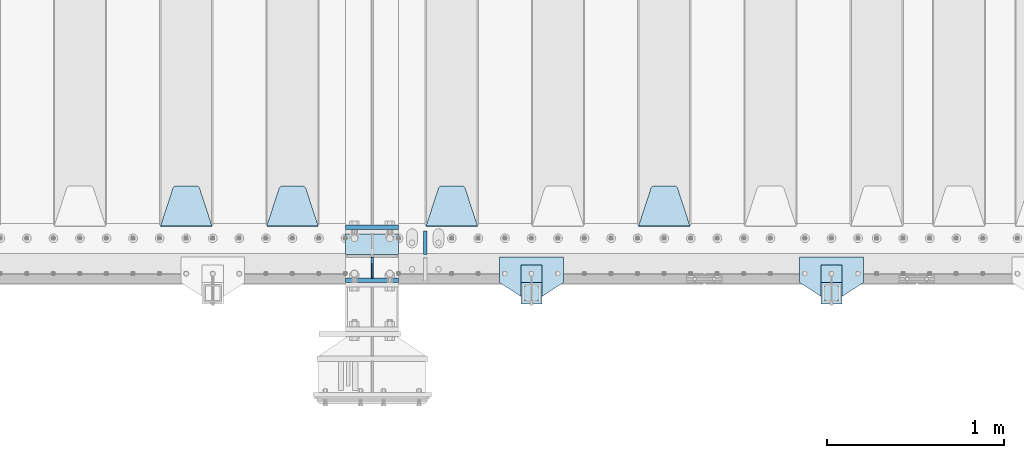
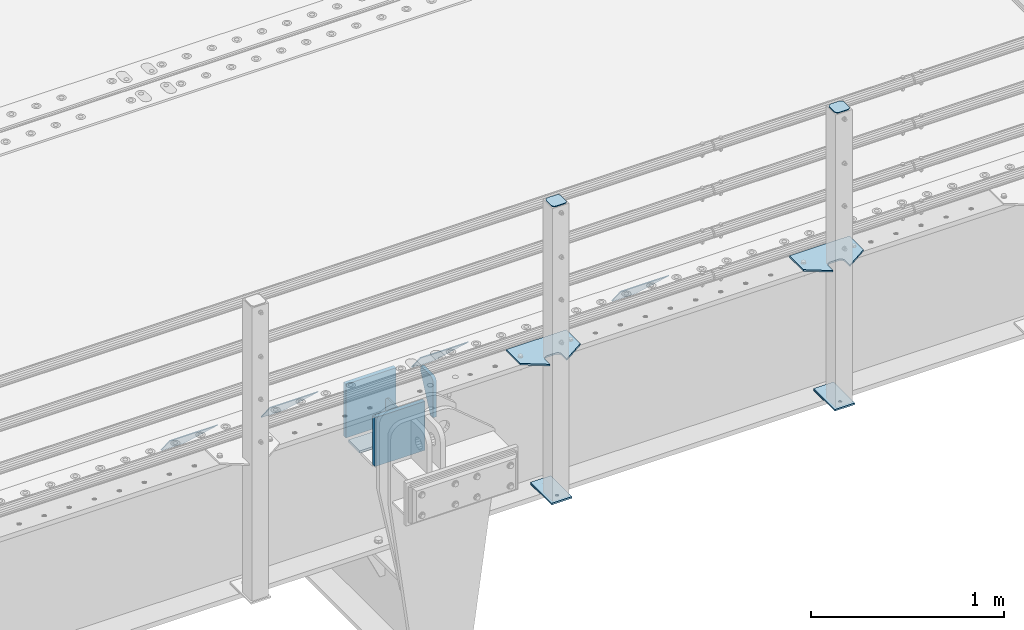
# One storey, part 206 of 247: 17 plates.
"""IFC2X3 building model written with IfcOpenShell, lengths in millimetres."""

from ifc_helpers import new_model, si_unit, frame, origin_with_axes, place, context, subcontext, project, spatial, faceted_brep, material, type_object, element, save


model = new_model("IFC2X3")

# Units and contexts
model_context = context("Model", 3, precision=1e-05, world=origin_with_axes())
body_context = subcontext(model_context, "Body", "Model", "MODEL_VIEW")
ifc_project = project(units=[si_unit("LENGTHUNIT", "METRE", prefix="MILLI"), si_unit("AREAUNIT", "SQUARE_METRE"), si_unit("VOLUMEUNIT", "CUBIC_METRE"), si_unit("MASSUNIT", "GRAM", prefix="KILO"), si_unit("TIMEUNIT", "SECOND"), si_unit("PLANEANGLEUNIT", "RADIAN"), si_unit("SOLIDANGLEUNIT", "STERADIAN"), si_unit("THERMODYNAMICTEMPERATUREUNIT", "DEGREE_CELSIUS"), si_unit("LUMINOUSINTENSITYUNIT", "LUMEN")], contexts=[model_context])

# Site, building, storey
site_placement = place(None, origin_with_axes())
site = spatial("IfcSite", under=ifc_project, at=site_placement, CompositionType="ELEMENT")
building_placement = place(site_placement, origin_with_axes())
building = spatial("IfcBuilding", under=site, at=building_placement, Name="Standard", CompositionType="ELEMENT")
storey_placement = place(building_placement, origin_with_axes())
storey = spatial("IfcBuildingStorey", under=building, at=storey_placement, Name="Undefined", CompositionType="ELEMENT", Elevation=0.0)

# Plates
ifc_material_1 = material(Name="STEEL/S355N")
plate_type_1 = type_object("IfcPlateType", PredefinedType="NOTDEFINED")
plate_1_placement = place(storey_placement, frame((12100.0, 162.5, -340.000000000044), z_axis=(0.0, 0.0, 1.0), x_axis=(1.0, 0.0, 0.0)))
element("IfcPlate", 1, at=plate_1_placement, inside=storey, type_object=plate_type_1, material=ifc_material_1, context=body_context, shape_type="Brep", body=[
    faceted_brep([(0.0, -12.5, 0.0), (0.0, -12.5, 340.0), (0.0, 12.5, 340.0), (0.0, 12.5, 0.0), (300.0, -12.5, 340.0), (300.0, 12.5, 340.0), (300.0, -12.5, 0.0), (300.0, 12.5, 0.0)], [[[0, 1, 2, 3]], [[1, 4, 5, 2]], [[4, 6, 7, 5]], [[6, 0, 3, 7]], [[5, 7, 3, 2]], [[6, 4, 1, 0]]]),
])
plate_2_placement = place(storey_placement, frame((12100.0, -137.5, -340.0), z_axis=(0.0, 0.0, 1.0), x_axis=(1.0, 0.0, 0.0)))
element("IfcPlate", 2, at=plate_2_placement, inside=storey, type_object=plate_type_1, material=ifc_material_1, context=body_context, shape_type="Brep", body=[
    faceted_brep([(0.0, -12.5, 0.0), (0.0, -12.5, 310.0), (0.0, 12.5, 310.0), (0.0, 12.5, 0.0), (300.0, -12.5, 310.0), (300.0, 12.5, 310.0), (300.0, -12.5, 0.0), (300.0, 12.5, 0.0)], [[[0, 1, 2, 3]], [[1, 4, 5, 2]], [[4, 6, 7, 5]], [[6, 0, 3, 7]], [[5, 7, 3, 2]], [[6, 4, 1, 0]]]),
])
plate_type_2 = type_object("IfcPlateType", PredefinedType="NOTDEFINED")
plate_3_placement = place(storey_placement, frame((12100.0, 8.0, -343.0), z_axis=(0.0, 1.0, 0.0), x_axis=(1.0, 0.0, 0.0)))
element("IfcPlate", 3, at=plate_3_placement, inside=storey, type_object=plate_type_2, material=ifc_material_1, context=body_context, shape_type="Brep", body=[
    faceted_brep([(0.0, -7.0, 0.0), (0.0, -7.0, 117.0), (0.0, 7.0, 117.0), (0.0, 7.0, 0.0), (300.0, -7.0, 117.0), (300.0, 7.0, 117.0), (300.0, -7.0, 0.0), (300.0, 7.0, 0.0)], [[[0, 1, 2, 3]], [[1, 4, 5, 2]], [[4, 6, 7, 5]], [[6, 0, 3, 7]], [[5, 7, 3, 2]], [[6, 4, 1, 0]]]),
])
plate_type_3 = type_object("IfcPlateType", PredefinedType="NOTDEFINED")
plate_4_placement = place(storey_placement, frame((12250.0, -8.0, -30.0), z_axis=(0.0, 0.0, -1.0), x_axis=(0.0, -0.999999999999548, -9.5100000000016e-07)))
element("IfcPlate", 4, at=plate_4_placement, inside=storey, type_object=plate_type_3, material=ifc_material_1, context=body_context, shape_type="Brep", body=[
    faceted_brep([(0.0, -5.0, 30.0), (0.0, -5.0, 306.0), (0.0, 5.0, 306.0), (0.0, 5.0, 30.0), (117.0, -5.0, 306.0), (117.0, 5.0, 306.0), (117.0, -5.0, 0.0), (117.0, 5.0, 0.0), (30.0, -5.0, 0.0), (30.0, 5.0, 0.0), (24.7905546699922, -5.0, 0.455767409633758), (24.7905546699922, 5.0, 0.455767409633758), (19.73939570023, -5.0, 1.80922137642275), (19.73939570023, 5.0, 1.80922137642275), (15.0, -5.0, 4.01923788646684), (15.0, 5.0, 4.01923788646684), (10.716371709404, -5.0, 7.01866670643066), (10.716371709404, 5.0, 7.01866670643066), (7.01866670643085, -5.0, 10.7163717094038), (7.01866670643085, 5.0, 10.7163717094038), (4.01923788646673, -5.0, 15.0), (4.01923788646673, 5.0, 15.0), (1.80922137642256, -5.0, 19.7393957002299), (1.80922137642256, 5.0, 19.7393957002299), (0.455767409633609, -5.0, 24.7905546699921), (0.455767409633609, 5.0, 24.7905546699921)], [[[0, 1, 2, 3]], [[1, 4, 5, 2]], [[4, 6, 7, 5]], [[6, 8, 9, 7]], [[8, 10, 11, 9]], [[10, 12, 13, 11]], [[12, 14, 15, 13]], [[14, 16, 17, 15]], [[16, 18, 19, 17]], [[18, 20, 21, 19]], [[20, 22, 23, 21]], [[22, 24, 25, 23]], [[24, 0, 3, 25]], [[5, 7, 9, 11, 13, 15, 17, 19, 21, 23, 25, 3, 2]], [[24, 22, 20, 18, 16, 14, 12, 10, 8, 6, 4, 1, 0]]]),
])
plate_type_4 = type_object("IfcPlateType", PredefinedType="NOTDEFINED")
plate_5_placement = place(storey_placement, frame((14045.0, 168.232233047034, -1.76776695296758), z_axis=(0.0, 0.707106781186548, -0.707106781186547), x_axis=(-1.0, 0.0, 0.0)))
element("IfcPlate", 5, at=plate_5_placement, inside=storey, type_object=plate_type_4, material=ifc_material_1, context=body_context, shape_type="Brep", body=[
    faceted_brep([(0.0, -2.49999999999909, 0.0), (69.345504679477, -2.5, 300.17173142483), (69.345504679477, 2.50000000000091, 300.171731424831), (0.0, 2.5, -9.09494701772928e-13), (70.9274061199576, -2.5, 304.897442415399), (70.9274061199576, 2.50000000000091, 304.8974424154), (73.3818627772307, -2.49999999999909, 309.234538108527), (73.3818627772307, 2.5, 309.234538108526), (76.6187032999551, -2.5, 313.023683126102), (76.6187032999551, 2.50000000000091, 313.023683126102), (80.5190132704993, -2.49999999999909, 316.125672595371), (80.5190132704993, 2.50000000000091, 316.125672595372), (84.9395038596849, -2.49999999999909, 318.426546230476), (84.9395038596849, 2.5, 318.426546230475), (89.7177759439219, -2.5, 319.841774983274), (89.7177759439219, 2.50000000000091, 319.841774983275), (94.678286292652, -2.5, 320.319366455077), (94.678286292652, 2.50000000000091, 320.319366455077), (195.321713707348, -2.5, 320.319366455077), (195.321713707348, 2.50000000000091, 320.319366455077), (200.282224056078, -2.5, 319.841774983274), (200.282224056078, 2.50000000000091, 319.841774983275), (205.060496140315, -2.5, 318.426546230475), (205.060496140315, 2.5, 318.426546230474), (209.480986729501, -2.49999999999818, 316.12567259537), (209.480986729501, 2.50000000000091, 316.12567259537), (213.381296700045, -2.5, 313.023683126101), (213.381296700045, 2.50000000000091, 313.023683126101), (216.618137222769, -2.5, 309.234538108525), (216.618137222769, 2.5, 309.234538108525), (219.072593880042, -2.49999999999909, 304.897442415398), (219.072593880042, 2.5, 304.897442415398), (220.654495320523, -2.5, 300.17173142483), (220.654495320523, 2.50000000000091, 300.171731424831), (290.0, -2.49999999999909, 0.0), (290.0, 2.5, -9.09494701772928e-13)], [[[0, 1, 2, 3]], [[1, 4, 5, 2]], [[4, 6, 7, 5]], [[6, 8, 9, 7]], [[8, 10, 11, 9]], [[10, 12, 13, 11]], [[12, 14, 15, 13]], [[14, 16, 17, 15]], [[16, 18, 19, 17]], [[18, 20, 21, 19]], [[20, 22, 23, 21]], [[22, 24, 25, 23]], [[24, 26, 27, 25]], [[26, 28, 29, 27]], [[28, 30, 31, 29]], [[30, 32, 33, 31]], [[32, 34, 35, 33]], [[34, 0, 3, 35]], [[5, 7, 9, 11, 13, 15, 17, 19, 21, 23, 25, 27, 29, 31, 33, 35, 3, 2]], [[34, 32, 30, 28, 26, 24, 22, 20, 18, 16, 14, 12, 10, 8, 6, 4, 1, 0]]]),
])
plate_6_placement = place(storey_placement, frame((12845.0, 168.232233047034, -1.76776695296758), z_axis=(0.0, 0.707106781186548, -0.707106781186547), x_axis=(-1.0, 0.0, 0.0)))
element("IfcPlate", 6, at=plate_6_placement, inside=storey, type_object=plate_type_4, material=ifc_material_1, context=body_context, shape_type="Brep", body=[
    faceted_brep([(0.0, -2.49999999999909, 0.0), (69.345504679477, -2.5, 300.17173142483), (69.345504679477, 2.50000000000091, 300.171731424831), (0.0, 2.5, -9.09494701772928e-13), (70.9274061199576, -2.5, 304.897442415399), (70.9274061199576, 2.50000000000091, 304.8974424154), (73.3818627772307, -2.49999999999909, 309.234538108527), (73.3818627772307, 2.5, 309.234538108526), (76.6187032999551, -2.5, 313.023683126102), (76.6187032999551, 2.50000000000091, 313.023683126102), (80.5190132704993, -2.49999999999909, 316.125672595371), (80.5190132704993, 2.50000000000091, 316.125672595372), (84.9395038596849, -2.49999999999909, 318.426546230476), (84.9395038596849, 2.5, 318.426546230475), (89.7177759439219, -2.5, 319.841774983274), (89.7177759439219, 2.50000000000091, 319.841774983275), (94.678286292652, -2.5, 320.319366455077), (94.678286292652, 2.50000000000091, 320.319366455077), (195.321713707348, -2.5, 320.319366455077), (195.321713707348, 2.50000000000091, 320.319366455077), (200.282224056078, -2.5, 319.841774983274), (200.282224056078, 2.50000000000091, 319.841774983275), (205.060496140315, -2.5, 318.426546230475), (205.060496140315, 2.5, 318.426546230474), (209.480986729501, -2.49999999999818, 316.12567259537), (209.480986729501, 2.50000000000091, 316.12567259537), (213.381296700045, -2.5, 313.023683126101), (213.381296700045, 2.50000000000091, 313.023683126101), (216.618137222769, -2.5, 309.234538108525), (216.618137222769, 2.5, 309.234538108525), (219.072593880042, -2.49999999999909, 304.897442415398), (219.072593880042, 2.5, 304.897442415398), (220.654495320523, -2.5, 300.17173142483), (220.654495320523, 2.50000000000091, 300.171731424831), (290.0, -2.49999999999909, 0.0), (290.0, 2.5, -9.09494701772928e-13)], [[[0, 1, 2, 3]], [[1, 4, 5, 2]], [[4, 6, 7, 5]], [[6, 8, 9, 7]], [[8, 10, 11, 9]], [[10, 12, 13, 11]], [[12, 14, 15, 13]], [[14, 16, 17, 15]], [[16, 18, 19, 17]], [[18, 20, 21, 19]], [[20, 22, 23, 21]], [[22, 24, 25, 23]], [[24, 26, 27, 25]], [[26, 28, 29, 27]], [[28, 30, 31, 29]], [[30, 32, 33, 31]], [[32, 34, 35, 33]], [[34, 0, 3, 35]], [[5, 7, 9, 11, 13, 15, 17, 19, 21, 23, 25, 27, 29, 31, 33, 35, 3, 2]], [[34, 32, 30, 28, 26, 24, 22, 20, 18, 16, 14, 12, 10, 8, 6, 4, 1, 0]]]),
])
plate_7_placement = place(storey_placement, frame((11945.0, 168.232233047034, -1.76776695296758), z_axis=(0.0, 0.707106781186548, -0.707106781186547), x_axis=(-1.0, 0.0, 0.0)))
element("IfcPlate", 7, at=plate_7_placement, inside=storey, type_object=plate_type_4, material=ifc_material_1, context=body_context, shape_type="Brep", body=[
    faceted_brep([(0.0, -2.49999999999909, 0.0), (69.345504679477, -2.5, 300.17173142483), (69.345504679477, 2.50000000000091, 300.171731424831), (0.0, 2.5, -9.09494701772928e-13), (70.9274061199576, -2.5, 304.897442415399), (70.9274061199576, 2.50000000000091, 304.8974424154), (73.3818627772307, -2.49999999999909, 309.234538108527), (73.3818627772307, 2.5, 309.234538108526), (76.6187032999551, -2.5, 313.023683126102), (76.6187032999551, 2.50000000000091, 313.023683126102), (80.5190132704993, -2.49999999999909, 316.125672595371), (80.5190132704993, 2.50000000000091, 316.125672595372), (84.9395038596849, -2.49999999999909, 318.426546230476), (84.9395038596849, 2.5, 318.426546230475), (89.7177759439219, -2.5, 319.841774983274), (89.7177759439219, 2.50000000000091, 319.841774983275), (94.678286292652, -2.5, 320.319366455077), (94.678286292652, 2.50000000000091, 320.319366455077), (195.321713707348, -2.5, 320.319366455077), (195.321713707348, 2.50000000000091, 320.319366455077), (200.282224056078, -2.5, 319.841774983274), (200.282224056078, 2.50000000000091, 319.841774983275), (205.060496140315, -2.5, 318.426546230475), (205.060496140315, 2.5, 318.426546230474), (209.480986729501, -2.49999999999818, 316.12567259537), (209.480986729501, 2.50000000000091, 316.12567259537), (213.381296700045, -2.5, 313.023683126101), (213.381296700045, 2.50000000000091, 313.023683126101), (216.618137222769, -2.5, 309.234538108525), (216.618137222769, 2.5, 309.234538108525), (219.072593880042, -2.49999999999909, 304.897442415398), (219.072593880042, 2.5, 304.897442415398), (220.654495320523, -2.5, 300.17173142483), (220.654495320523, 2.50000000000091, 300.171731424831), (290.0, -2.49999999999909, 0.0), (290.0, 2.5, -9.09494701772928e-13)], [[[0, 1, 2, 3]], [[1, 4, 5, 2]], [[4, 6, 7, 5]], [[6, 8, 9, 7]], [[8, 10, 11, 9]], [[10, 12, 13, 11]], [[12, 14, 15, 13]], [[14, 16, 17, 15]], [[16, 18, 19, 17]], [[18, 20, 21, 19]], [[20, 22, 23, 21]], [[22, 24, 25, 23]], [[24, 26, 27, 25]], [[26, 28, 29, 27]], [[28, 30, 31, 29]], [[30, 32, 33, 31]], [[32, 34, 35, 33]], [[34, 0, 3, 35]], [[5, 7, 9, 11, 13, 15, 17, 19, 21, 23, 25, 27, 29, 31, 33, 35, 3, 2]], [[34, 32, 30, 28, 26, 24, 22, 20, 18, 16, 14, 12, 10, 8, 6, 4, 1, 0]]]),
])
plate_8_placement = place(storey_placement, frame((11345.0, 168.232233047034, -1.76776695296758), z_axis=(0.0, 0.707106781186548, -0.707106781186547), x_axis=(-1.0, 0.0, 0.0)))
element("IfcPlate", 8, at=plate_8_placement, inside=storey, type_object=plate_type_4, material=ifc_material_1, context=body_context, shape_type="Brep", body=[
    faceted_brep([(0.0, -2.49999999999909, 0.0), (69.345504679477, -2.5, 300.17173142483), (69.345504679477, 2.50000000000091, 300.171731424831), (0.0, 2.5, -9.09494701772928e-13), (70.9274061199576, -2.5, 304.897442415399), (70.9274061199576, 2.50000000000091, 304.8974424154), (73.3818627772307, -2.49999999999909, 309.234538108527), (73.3818627772307, 2.5, 309.234538108526), (76.6187032999551, -2.5, 313.023683126102), (76.6187032999551, 2.50000000000091, 313.023683126102), (80.5190132704993, -2.49999999999909, 316.125672595371), (80.5190132704993, 2.50000000000091, 316.125672595372), (84.9395038596849, -2.49999999999909, 318.426546230476), (84.9395038596849, 2.5, 318.426546230475), (89.7177759439219, -2.5, 319.841774983274), (89.7177759439219, 2.50000000000091, 319.841774983275), (94.678286292652, -2.5, 320.319366455077), (94.678286292652, 2.50000000000091, 320.319366455077), (195.321713707348, -2.5, 320.319366455077), (195.321713707348, 2.50000000000091, 320.319366455077), (200.282224056078, -2.5, 319.841774983274), (200.282224056078, 2.50000000000091, 319.841774983275), (205.060496140315, -2.5, 318.426546230475), (205.060496140315, 2.5, 318.426546230474), (209.480986729501, -2.49999999999818, 316.12567259537), (209.480986729501, 2.50000000000091, 316.12567259537), (213.381296700045, -2.5, 313.023683126101), (213.381296700045, 2.50000000000091, 313.023683126101), (216.618137222769, -2.5, 309.234538108525), (216.618137222769, 2.5, 309.234538108525), (219.072593880042, -2.49999999999909, 304.897442415398), (219.072593880042, 2.5, 304.897442415398), (220.654495320523, -2.5, 300.17173142483), (220.654495320523, 2.50000000000091, 300.171731424831), (290.0, -2.49999999999909, 0.0), (290.0, 2.5, -9.09494701772928e-13)], [[[0, 1, 2, 3]], [[1, 4, 5, 2]], [[4, 6, 7, 5]], [[6, 8, 9, 7]], [[8, 10, 11, 9]], [[10, 12, 13, 11]], [[12, 14, 15, 13]], [[14, 16, 17, 15]], [[16, 18, 19, 17]], [[18, 20, 21, 19]], [[20, 22, 23, 21]], [[22, 24, 25, 23]], [[24, 26, 27, 25]], [[26, 28, 29, 27]], [[28, 30, 31, 29]], [[30, 32, 33, 31]], [[32, 34, 35, 33]], [[34, 0, 3, 35]], [[5, 7, 9, 11, 13, 15, 17, 19, 21, 23, 25, 27, 29, 31, 33, 35, 3, 2]], [[34, 32, 30, 28, 26, 24, 22, 20, 18, 16, 14, 12, 10, 8, 6, 4, 1, 0]]]),
])
plate_type_5 = type_object("IfcPlateType", PredefinedType="NOTDEFINED")
plate_9_placement = place(storey_placement, frame((12550.0, 140.0, -30.0), z_axis=(0.0, 0.0, -1.0), x_axis=(0.0, -0.999999999999548, -9.5100000000016e-07)))
element("IfcPlate", 9, at=plate_9_placement, inside=storey, type_object=plate_type_5, material=ifc_material_1, context=body_context, shape_type="Brep", body=[
    faceted_brep([(-5.6843418860808e-14, -9.99999999999989, 3.5527136788005e-15), (0.0, -10.0, 30.0), (0.0, 10.0, 30.0), (-5.6843418860808e-14, 10.0000000000001, 3.5527136788005e-15), (102.0, -10.0, 250.0), (102.0, 10.0, 250.0), (132.0, -10.0, 250.0), (132.0, 10.0, 250.0), (132.0, -10.0, 30.0), (132.0, 10.0, 30.0), (131.544232590366, -10.0, 24.790554669992), (131.544232590366, 10.0, 24.790554669992), (130.190778623577, -10.0, 19.7393957002299), (130.190778623577, 10.0, 19.7393957002299), (127.980762113533, -10.0, 15.0), (127.980762113533, 10.0, 15.0), (124.981333293569, -10.0, 10.7163717094038), (124.981333293569, 10.0, 10.7163717094038), (121.283628290596, -10.0, 7.01866670643062), (121.283628290596, 10.0, 7.01866670643062), (117.0, -10.0, 4.01923788646684), (117.0, 10.0, 4.01923788646684), (112.26060429977, -10.0, 1.80922137642278), (112.26060429977, 10.0, 1.80922137642278), (107.209445330008, -10.0, 0.455767409633722), (107.209445330008, 10.0, 0.455767409633722), (102.0, -10.0, 0.0), (102.0, 10.0, 0.0)], [[[0, 1, 2, 3]], [[1, 4, 5, 2]], [[4, 6, 7, 5]], [[6, 8, 9, 7]], [[8, 10, 11, 9]], [[10, 12, 13, 11]], [[12, 14, 15, 13]], [[14, 16, 17, 15]], [[16, 18, 19, 17]], [[18, 20, 21, 19]], [[20, 22, 23, 21]], [[22, 24, 25, 23]], [[24, 26, 27, 25]], [[26, 0, 3, 27]], [[5, 7, 9, 11, 13, 15, 17, 19, 21, 23, 25, 27, 3, 2]], [[26, 24, 22, 20, 18, 16, 14, 12, 10, 8, 6, 4, 1, 0]]]),
])
ifc_material_2 = material(Name="STEEL/S355J2")
plate_type_6 = type_object("IfcPlateType", PredefinedType="NOTDEFINED")
plate_10_placement = place(storey_placement, frame((15025.0, -4.99999999999636, 5.00000000004911), z_axis=(0.0, -0.999999999999548, -9.5100000000016e-07), x_axis=(-1.0, 0.0, 0.0)))
element("IfcPlate", 10, at=plate_10_placement, inside=storey, type_object=plate_type_6, material=ifc_material_2, context=body_context, shape_type="Brep", body=[
    faceted_brep([(9.04219632502645e-09, -5.00000000143385, -2.89173840428703e-09), (2.31396552408114e-06, -5.0, 145.0), (2.31396552408114e-06, 5.0, 145.0), (7.66340235713869e-09, 4.99999999856618, -2.89173840428703e-09), (130.0, -5.0, 230.0), (130.0, 5.0, 230.0), (130.0, -5.0, 180.0), (130.0, 5.0, 180.0), (130.48036798992, -5.0, 175.122741949597), (130.48036798992, 5.0, 175.122741949597), (131.903011687218, -5.0, 170.432914190873), (131.903011687218, 5.0, 170.432914190873), (134.213259692437, -5.0, 166.11074417451), (134.213259692437, 5.0, 166.11074417451), (137.322330470337, -5.0, 162.322330470337), (137.322330470337, 5.0, 162.322330470337), (141.11074417451, -5.0, 159.213259692437), (141.11074417451, 5.0, 159.213259692437), (145.432914190873, -5.0, 156.903011687218), (145.432914190873, 5.0, 156.903011687218), (150.122741949597, -5.0, 155.48036798992), (150.122741949597, 5.0, 155.48036798992), (155.0, -5.0, 155.0), (155.0, 5.0, 155.0), (205.0, -5.0, 155.0), (205.0, 5.0, 155.0), (209.877258050403, -5.0, 155.48036798992), (209.877258050403, 5.0, 155.48036798992), (214.567085809127, -5.0, 156.903011687218), (214.567085809127, 5.0, 156.903011687218), (218.88925582549, -5.0, 159.213259692437), (218.88925582549, 5.0, 159.213259692437), (222.677669529663, -5.0, 162.322330470337), (222.677669529663, 5.0, 162.322330470337), (225.786740307563, -5.0, 166.11074417451), (225.786740307563, 5.0, 166.11074417451), (228.096988312782, -5.0, 170.432914190873), (228.096988312782, 5.0, 170.432914190873), (229.51963201008, -5.0, 175.122741949597), (229.51963201008, 5.0, 175.122741949597), (230.0, -5.0, 180.0), (230.0, 5.0, 180.0), (230.0, -5.0, 230.0), (230.0, 5.0, 230.0), (360.0, -5.0, 145.0), (360.0, 5.0, 145.0), (360.0, -5.0, -7.27595761418343e-12), (360.0, 5.0, -7.27595761418343e-12)], [[[0, 1, 2, 3]], [[1, 4, 5, 2]], [[4, 6, 7, 5]], [[6, 8, 9, 7]], [[8, 10, 11, 9]], [[10, 12, 13, 11]], [[12, 14, 15, 13]], [[14, 16, 17, 15]], [[16, 18, 19, 17]], [[18, 20, 21, 19]], [[20, 22, 23, 21]], [[22, 24, 25, 23]], [[24, 26, 27, 25]], [[26, 28, 29, 27]], [[28, 30, 31, 29]], [[30, 32, 33, 31]], [[32, 34, 35, 33]], [[34, 36, 37, 35]], [[36, 38, 39, 37]], [[38, 40, 41, 39]], [[40, 42, 43, 41]], [[42, 44, 45, 43]], [[44, 46, 47, 45]], [[46, 0, 3, 47]], [[5, 7, 9, 11, 13, 15, 17, 19, 21, 23, 25, 27, 29, 31, 33, 35, 37, 39, 41, 43, 45, 47, 3, 2]], [[46, 44, 42, 40, 38, 36, 34, 32, 30, 28, 26, 24, 22, 20, 18, 16, 14, 12, 10, 8, 6, 4, 1, 0]]]),
])
plate_11_placement = place(storey_placement, frame((13330.0, -4.99999999999636, 5.00000000004911), z_axis=(0.0, -0.999999999999548, -9.5100000000016e-07), x_axis=(-1.0, 0.0, 0.0)))
element("IfcPlate", 11, at=plate_11_placement, inside=storey, type_object=plate_type_6, material=ifc_material_2, context=body_context, shape_type="Brep", body=[
    faceted_brep([(9.04219632502645e-09, -5.00000000143385, -2.89173840428703e-09), (2.31396552408114e-06, -5.0, 145.0), (2.31396552408114e-06, 5.0, 145.0), (7.66340235713869e-09, 4.99999999856618, -2.89173840428703e-09), (130.0, -5.0, 230.0), (130.0, 5.0, 230.0), (130.0, -5.0, 180.0), (130.0, 5.0, 180.0), (130.48036798992, -5.0, 175.122741949597), (130.48036798992, 5.0, 175.122741949597), (131.903011687218, -5.0, 170.432914190873), (131.903011687218, 5.0, 170.432914190873), (134.213259692437, -5.0, 166.11074417451), (134.213259692437, 5.0, 166.11074417451), (137.322330470337, -5.0, 162.322330470337), (137.322330470337, 5.0, 162.322330470337), (141.11074417451, -5.0, 159.213259692437), (141.11074417451, 5.0, 159.213259692437), (145.432914190873, -5.0, 156.903011687218), (145.432914190873, 5.0, 156.903011687218), (150.122741949597, -5.0, 155.48036798992), (150.122741949597, 5.0, 155.48036798992), (155.0, -5.0, 155.0), (155.0, 5.0, 155.0), (205.0, -5.0, 155.0), (205.0, 5.0, 155.0), (209.877258050403, -5.0, 155.48036798992), (209.877258050403, 5.0, 155.48036798992), (214.567085809127, -5.0, 156.903011687218), (214.567085809127, 5.0, 156.903011687218), (218.88925582549, -5.0, 159.213259692437), (218.88925582549, 5.0, 159.213259692437), (222.677669529663, -5.0, 162.322330470337), (222.677669529663, 5.0, 162.322330470337), (225.786740307563, -5.0, 166.11074417451), (225.786740307563, 5.0, 166.11074417451), (228.096988312782, -5.0, 170.432914190873), (228.096988312782, 5.0, 170.432914190873), (229.51963201008, -5.0, 175.122741949597), (229.51963201008, 5.0, 175.122741949597), (230.0, -5.0, 180.0), (230.0, 5.0, 180.0), (230.0, -5.0, 230.0), (230.0, 5.0, 230.0), (360.0, -5.0, 145.0), (360.0, 5.0, 145.0), (360.0, -5.0, -7.27595761418343e-12), (360.0, 5.0, -7.27595761418343e-12)], [[[0, 1, 2, 3]], [[1, 4, 5, 2]], [[4, 6, 7, 5]], [[6, 8, 9, 7]], [[8, 10, 11, 9]], [[10, 12, 13, 11]], [[12, 14, 15, 13]], [[14, 16, 17, 15]], [[16, 18, 19, 17]], [[18, 20, 21, 19]], [[20, 22, 23, 21]], [[22, 24, 25, 23]], [[24, 26, 27, 25]], [[26, 28, 29, 27]], [[28, 30, 31, 29]], [[30, 32, 33, 31]], [[32, 34, 35, 33]], [[34, 36, 37, 35]], [[36, 38, 39, 37]], [[38, 40, 41, 39]], [[40, 42, 43, 41]], [[42, 44, 45, 43]], [[44, 46, 47, 45]], [[46, 0, 3, 47]], [[5, 7, 9, 11, 13, 15, 17, 19, 21, 23, 25, 27, 29, 31, 33, 35, 37, 39, 41, 43, 45, 47, 3, 2]], [[46, 44, 42, 40, 38, 36, 34, 32, 30, 28, 26, 24, 22, 20, 18, 16, 14, 12, 10, 8, 6, 4, 1, 0]]]),
])
plate_type_7 = type_object("IfcPlateType", PredefinedType="NOTDEFINED")
for number, where, z_axis, x_axis in (
    (12, (14904.9999999999, -50.0000000002074, -850.000000000002), (0.0, -0.999999999999548, -9.5100000000016e-07), (-1.0, 0.0, 0.0)),
    (13, (13209.9999999999, -50.0000000002074, -850.000000000002), (0.0, -0.999999999999548, -9.5100000000016e-07), (-1.0, 0.0, 0.0)),
):
    element("IfcPlate", number, at=place(storey_placement, frame(where, z_axis=z_axis, x_axis=x_axis)), inside=storey, type_object=plate_type_7, material=ifc_material_2, context=body_context, shape_type="Brep", body=[
        faceted_brep([(53.6360389691836, -5.0, 176.363961030469), (53.6360389691836, 5.0, 176.363961030469), (59.9999999998618, 5.0, 178.999999999791), (59.9999999998618, -5.0, 178.999999999791), (66.3639610305399, 5.0, 176.363961030469), (66.3639610305399, -5.0, 176.363961030469), (68.9999999998618, 5.0, 169.999999999791), (68.9999999998618, -5.0, 169.999999999791), (66.3639610305399, 5.0, 163.636038969113), (66.3639610305399, -5.0, 163.636038969113), (59.9999999998618, 5.0, 160.999999999791), (59.9999999998618, -5.0, 160.999999999791), (53.6360389691836, 5.0, 163.636038969113), (53.6360389691836, -5.0, 163.636038969113), (50.9999999998618, 5.0, 169.999999999791), (50.9999999998618, -5.0, 169.999999999791), (120.0, -5.0, 0.0), (120.0, -5.0, 220.0), (0.0, -5.0, 220.0), (9.04219632502645e-09, -5.00000000143385, -2.89173840428703e-09), (7.66340235713869e-09, 4.99999999856618, -2.89173840428703e-09), (120.0, 5.0, 0.0), (120.0, 5.0, 220.0), (0.0, 5.0, 220.0)], [[[0, 1, 2, 3]], [[3, 2, 4, 5]], [[5, 4, 6, 7]], [[7, 6, 8, 9]], [[9, 8, 10, 11]], [[11, 10, 12, 13]], [[13, 12, 14, 15]], [[15, 14, 1, 0]], [[16, 17, 18, 19], [11, 13, 15, 0, 3, 5, 7, 9]], [[16, 19, 20, 21]], [[17, 16, 21, 22]], [[18, 17, 22, 23]], [[19, 18, 23, 20]], [[22, 21, 20, 23], [2, 1, 14, 12, 10, 8, 6, 4]]]),
    ])
plate_type_8 = type_object("IfcPlateType", PredefinedType="NOTDEFINED")
plate_12_placement = place(storey_placement, frame((14800.9999999999, -166.000000000207, 1012.50000000001), z_axis=(0.0, -0.999999999999548, -9.5100000000016e-07), x_axis=(1.0, 0.0, 0.0)))
element("IfcPlate", 14, at=plate_12_placement, inside=storey, type_object=plate_type_8, material=ifc_material_2, context=body_context, shape_type="Brep", body=[
    faceted_brep([(0.0, -2.5, 19.0), (0.0, -2.5, 69.0), (0.0, 2.5, 69.0), (0.0, 2.5, 19.0), (0.476369668545885, -2.5, 73.2278977451697), (0.476369668545885, 2.5, 73.2278977451697), (1.88159150985484, -2.5, 77.2437910432327), (1.88159150985484, 2.5, 77.2437910432327), (4.14520183310742, -2.5, 80.8463062353167), (4.14520183310742, 2.5, 80.8463062353167), (7.15369376468334, -2.5, 83.8547981668926), (7.15369376468334, 2.5, 83.8547981668926), (10.7562089567673, -2.5, 86.1184084901452), (10.7562089567673, 2.5, 86.1184084901452), (14.7721022548303, -2.5, 87.5236303314541), (14.7721022548303, 2.5, 87.5236303314541), (19.0, -2.5, 88.0), (19.0, 2.5, 88.0), (69.0, -2.5, 88.0), (69.0, 2.5, 88.0), (73.2278977451697, -2.5, 87.5236303314541), (73.2278977451697, 2.5, 87.5236303314541), (77.2437910432327, -2.5, 86.1184084901452), (77.2437910432327, 2.5, 86.1184084901452), (80.8463062353167, -2.5, 83.8547981668926), (80.8463062353167, 2.5, 83.8547981668926), (83.8547981668926, -2.5, 80.8463062353167), (83.8547981668926, 2.5, 80.8463062353167), (86.1184084901452, -2.5, 77.2437910432327), (86.1184084901452, 2.5, 77.2437910432327), (87.5236303314541, -2.5, 73.2278977451697), (87.5236303314541, 2.5, 73.2278977451697), (88.0, -2.5, 69.0), (88.0, 2.5, 69.0), (88.0, -2.5, 19.0), (88.0, 2.5, 19.0), (87.5236303314541, -2.5, 14.7721022548303), (87.5236303314541, 2.5, 14.7721022548303), (86.1184084901452, -2.5, 10.7562089567673), (86.1184084901452, 2.5, 10.7562089567673), (83.8547981668926, -2.5, 7.15369376468334), (83.8547981668926, 2.5, 7.15369376468334), (80.8463062353167, -2.5, 4.14520183310742), (80.8463062353167, 2.5, 4.14520183310742), (77.2437910432345, -2.5, 1.88159150985484), (77.2437910432345, 2.5, 1.88159150985484), (73.2278977451697, -2.5, 0.476369668545885), (73.2278977451697, 2.5, 0.476369668545885), (69.0, -2.5, 0.0), (69.0, 2.5, 0.0), (19.0, -2.5, 0.0), (19.0, 2.5, 0.0), (14.7721022548303, -2.5, 0.476369668545885), (14.7721022548303, 2.5, 0.476369668545885), (10.7562089567673, -2.5, 1.88159150985484), (10.7562089567673, 2.5, 1.88159150985484), (7.15369376468334, -2.5, 4.14520183310742), (7.15369376468334, 2.5, 4.14520183310742), (4.14520183310742, -2.5, 7.15369376468334), (4.14520183310742, 2.5, 7.15369376468334), (1.88159150985484, -2.5, 10.7562089567673), (1.88159150985484, 2.5, 10.7562089567673), (0.476369668545885, -2.5, 14.7721022548303), (0.476369668545885, 2.5, 14.7721022548303)], [[[0, 1, 2, 3]], [[1, 4, 5, 2]], [[4, 6, 7, 5]], [[6, 8, 9, 7]], [[8, 10, 11, 9]], [[10, 12, 13, 11]], [[12, 14, 15, 13]], [[14, 16, 17, 15]], [[16, 18, 19, 17]], [[18, 20, 21, 19]], [[20, 22, 23, 21]], [[22, 24, 25, 23]], [[24, 26, 27, 25]], [[26, 28, 29, 27]], [[28, 30, 31, 29]], [[30, 32, 33, 31]], [[32, 34, 35, 33]], [[34, 36, 37, 35]], [[36, 38, 39, 37]], [[38, 40, 41, 39]], [[40, 42, 43, 41]], [[42, 44, 45, 43]], [[44, 46, 47, 45]], [[46, 48, 49, 47]], [[48, 50, 51, 49]], [[50, 52, 53, 51]], [[52, 54, 55, 53]], [[54, 56, 57, 55]], [[56, 58, 59, 57]], [[58, 60, 61, 59]], [[60, 62, 63, 61]], [[62, 0, 3, 63]], [[5, 7, 9, 11, 13, 15, 17, 19, 21, 23, 25, 27, 29, 31, 33, 35, 37, 39, 41, 43, 45, 47, 49, 51, 53, 55, 57, 59, 61, 63, 3, 2]], [[62, 60, 58, 56, 54, 52, 50, 48, 46, 44, 42, 40, 38, 36, 34, 32, 30, 28, 26, 24, 22, 20, 18, 16, 14, 12, 10, 8, 6, 4, 1, 0]]]),
])
plate_13_placement = place(storey_placement, frame((13105.9999999999, -166.000000000207, 1012.50000000001), z_axis=(0.0, -0.999999999999548, -9.5100000000016e-07), x_axis=(1.0, 0.0, 0.0)))
element("IfcPlate", 15, at=plate_13_placement, inside=storey, type_object=plate_type_8, material=ifc_material_2, context=body_context, shape_type="Brep", body=[
    faceted_brep([(0.0, -2.5, 19.0), (0.0, -2.5, 69.0), (0.0, 2.5, 69.0), (0.0, 2.5, 19.0), (0.476369668545885, -2.5, 73.2278977451697), (0.476369668545885, 2.5, 73.2278977451697), (1.88159150985484, -2.5, 77.2437910432327), (1.88159150985484, 2.5, 77.2437910432327), (4.14520183310742, -2.5, 80.8463062353167), (4.14520183310742, 2.5, 80.8463062353167), (7.15369376468334, -2.5, 83.8547981668926), (7.15369376468334, 2.5, 83.8547981668926), (10.7562089567673, -2.5, 86.1184084901452), (10.7562089567673, 2.5, 86.1184084901452), (14.7721022548303, -2.5, 87.5236303314541), (14.7721022548303, 2.5, 87.5236303314541), (19.0, -2.5, 88.0), (19.0, 2.5, 88.0), (69.0, -2.5, 88.0), (69.0, 2.5, 88.0), (73.2278977451697, -2.5, 87.5236303314541), (73.2278977451697, 2.5, 87.5236303314541), (77.2437910432327, -2.5, 86.1184084901452), (77.2437910432327, 2.5, 86.1184084901452), (80.8463062353167, -2.5, 83.8547981668926), (80.8463062353167, 2.5, 83.8547981668926), (83.8547981668926, -2.5, 80.8463062353167), (83.8547981668926, 2.5, 80.8463062353167), (86.1184084901452, -2.5, 77.2437910432327), (86.1184084901452, 2.5, 77.2437910432327), (87.5236303314541, -2.5, 73.2278977451697), (87.5236303314541, 2.5, 73.2278977451697), (88.0, -2.5, 69.0), (88.0, 2.5, 69.0), (88.0, -2.5, 19.0), (88.0, 2.5, 19.0), (87.5236303314541, -2.5, 14.7721022548303), (87.5236303314541, 2.5, 14.7721022548303), (86.1184084901452, -2.5, 10.7562089567673), (86.1184084901452, 2.5, 10.7562089567673), (83.8547981668926, -2.5, 7.15369376468334), (83.8547981668926, 2.5, 7.15369376468334), (80.8463062353167, -2.5, 4.14520183310742), (80.8463062353167, 2.5, 4.14520183310742), (77.2437910432345, -2.5, 1.88159150985484), (77.2437910432345, 2.5, 1.88159150985484), (73.2278977451697, -2.5, 0.476369668545885), (73.2278977451697, 2.5, 0.476369668545885), (69.0, -2.5, 0.0), (69.0, 2.5, 0.0), (19.0, -2.5, 0.0), (19.0, 2.5, 0.0), (14.7721022548303, -2.5, 0.476369668545885), (14.7721022548303, 2.5, 0.476369668545885), (10.7562089567673, -2.5, 1.88159150985484), (10.7562089567673, 2.5, 1.88159150985484), (7.15369376468334, -2.5, 4.14520183310742), (7.15369376468334, 2.5, 4.14520183310742), (4.14520183310742, -2.5, 7.15369376468334), (4.14520183310742, 2.5, 7.15369376468334), (1.88159150985484, -2.5, 10.7562089567673), (1.88159150985484, 2.5, 10.7562089567673), (0.476369668545885, -2.5, 14.7721022548303), (0.476369668545885, 2.5, 14.7721022548303)], [[[0, 1, 2, 3]], [[1, 4, 5, 2]], [[4, 6, 7, 5]], [[6, 8, 9, 7]], [[8, 10, 11, 9]], [[10, 12, 13, 11]], [[12, 14, 15, 13]], [[14, 16, 17, 15]], [[16, 18, 19, 17]], [[18, 20, 21, 19]], [[20, 22, 23, 21]], [[22, 24, 25, 23]], [[24, 26, 27, 25]], [[26, 28, 29, 27]], [[28, 30, 31, 29]], [[30, 32, 33, 31]], [[32, 34, 35, 33]], [[34, 36, 37, 35]], [[36, 38, 39, 37]], [[38, 40, 41, 39]], [[40, 42, 43, 41]], [[42, 44, 45, 43]], [[44, 46, 47, 45]], [[46, 48, 49, 47]], [[48, 50, 51, 49]], [[50, 52, 53, 51]], [[52, 54, 55, 53]], [[54, 56, 57, 55]], [[56, 58, 59, 57]], [[58, 60, 61, 59]], [[60, 62, 63, 61]], [[62, 0, 3, 63]], [[5, 7, 9, 11, 13, 15, 17, 19, 21, 23, 25, 27, 29, 31, 33, 35, 37, 39, 41, 43, 45, 47, 49, 51, 53, 55, 57, 59, 61, 63, 3, 2]], [[62, 60, 58, 56, 54, 52, 50, 48, 46, 44, 42, 40, 38, 36, 34, 32, 30, 28, 26, 24, 22, 20, 18, 16, 14, 12, 10, 8, 6, 4, 1, 0]]]),
])
plate_type_9 = type_object("IfcPlateType", PredefinedType="NOTDEFINED")
for number, where, z_axis, x_axis in (
    (16, (14904.9999999999, -50.0000000002074, -857.500000000002), (0.0, -0.999999999999548, -9.5100000000016e-07), (-1.0, 0.0, 0.0)),
    (17, (13209.9999999999, -50.0000000002074, -857.500000000002), (0.0, -0.999999999999548, -9.5100000000016e-07), (-1.0, 0.0, 0.0)),
):
    element("IfcPlate", number, at=place(storey_placement, frame(where, z_axis=z_axis, x_axis=x_axis)), inside=storey, type_object=plate_type_9, material=ifc_material_2, context=body_context, shape_type="Brep", body=[
        faceted_brep([(0.0, -2.49999999999909, 0.0), (0.0, -2.5, 100.0), (0.0, 2.5, 100.0), (0.0, 2.5, -9.09494701772928e-13), (120.0, -2.5, 100.0), (120.0, 2.5, 100.0), (120.0, -2.5, 0.0), (120.0, 2.5, 0.0)], [[[0, 1, 2, 3]], [[1, 4, 5, 2]], [[4, 6, 7, 5]], [[6, 0, 3, 7]], [[5, 7, 3, 2]], [[6, 4, 1, 0]]]),
    ])

save(model, "model.ifc")
